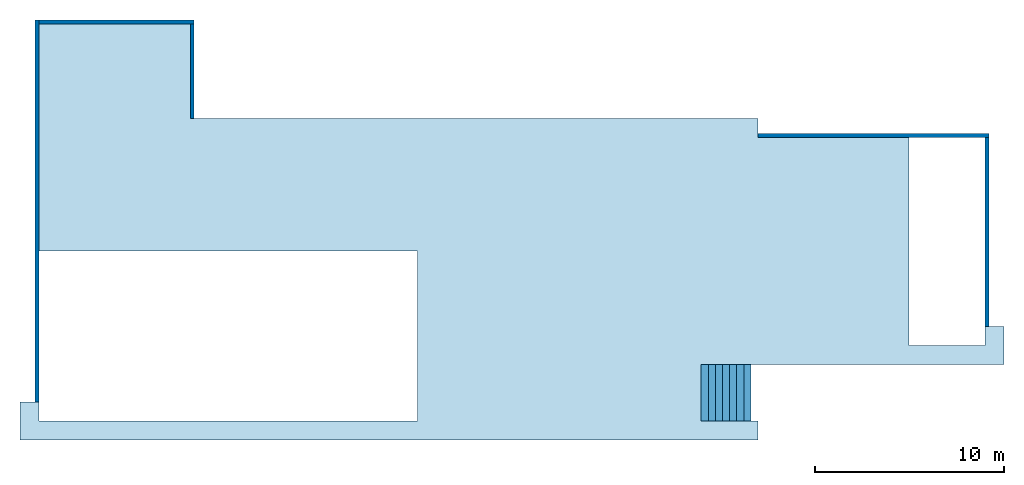
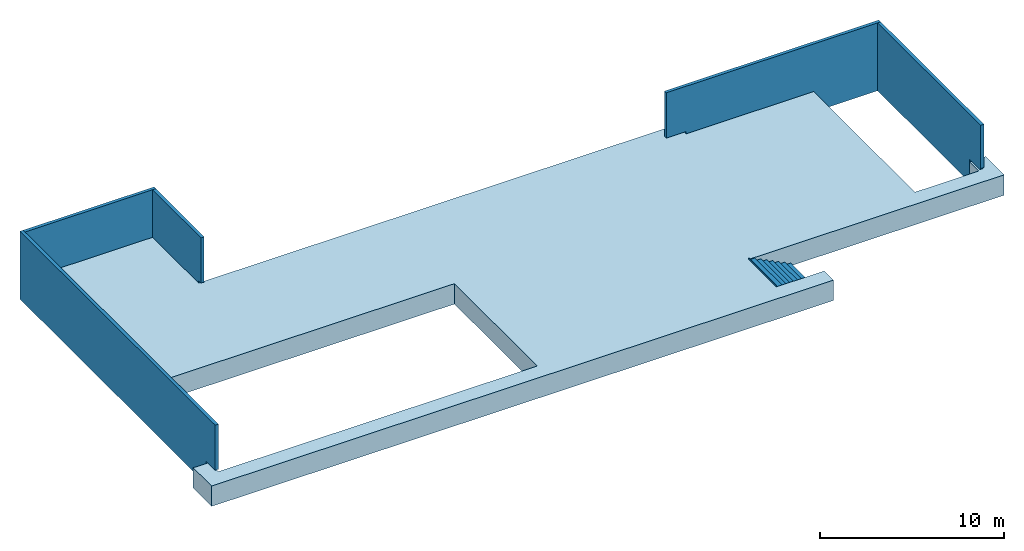
# One storey: 5 walls, 1 slab, 1 stair, 4 openings, 1 element without a shape of its own.
"""IFC2X3 building model written with IfcOpenShell, lengths in millimetres."""

from ifc_helpers import new_model, entity, si_unit, converted_unit, direction, frame, frame_2d, origin, place, context, subcontext, project, spatial, polyline, rectangle, outline, extrude, clip, halfspace, material, layer, layer_set, layer_usage, element, aggregate, save


model = new_model("IFC2X3")

# Units and contexts
model_context = context("Model", 3, precision=1e-06, world=origin(), true_north=direction((2.0, 6.12303176911189e-17, 1.0)))
context_of_model = context(None, 3, precision=1e-06, world=origin(), true_north=direction((2.0, 6.12303176911189e-17, 1.0)))
body_context = subcontext(model_context, "Body", "Model", "MODEL_VIEW")
ifc_project = project(units=[si_unit("LENGTHUNIT", "METRE", prefix="MILLI"), si_unit("AREAUNIT", "SQUARE_METRE", prefix="MILLI"), si_unit("VOLUMEUNIT", "CUBIC_METRE", prefix="MILLI"), converted_unit("PLANEANGLEUNIT", "DEGREE", entity("IfcRatioMeasure", 0.0174532925199433), si_unit("PLANEANGLEUNIT", "RADIAN"), dimensions=[0, 0, 0, 0, 0, 0, 0]), si_unit("TIMEUNIT", "SECOND")], contexts=[model_context, context_of_model])

# Site, building, storey
site_placement = place(None, origin())
site = spatial("IfcSite", under=ifc_project, at=site_placement, CompositionType="ELEMENT")
building_placement = place(site_placement, origin())
building = spatial("IfcBuilding", under=site, at=building_placement, CompositionType="ELEMENT")
storey_placement = place(building_placement, origin())
storey = spatial("IfcBuildingStorey", under=building, at=storey_placement, Name="Level 0", CompositionType="ELEMENT", Elevation=0.0)

# Slab
ifc_material_1 = material(Name="Default Floor")
ifc_layer_1 = layer(ifc_material_1, 1350.0)
ifc_layer_set_1 = layer_set([ifc_layer_1], Name="Floor:Generic 1350mm")
ifc_layer_usage_1 = layer_usage(ifc_layer_set_1, "AXIS3", "POSITIVE", 0.0)
slab_placement = place(storey_placement, origin())
element("IfcSlab", 1, at=slab_placement, inside=storey, material=ifc_layer_usage_1, Name="Floor:Generic 1350mm", ObjectType="Floor:Generic 1350mm", PredefinedType="FLOOR", context=body_context, shape_type="SweptSolid", body=[
    extrude(outline(polyline([(26000.0, -9000.0), (25000.0, -9000.0), (25000.0, -10000.0), (5000.0, -10000.0), (5000.0, -1000.0), (25000.0, -1000.0), (25000.0, 11000.0), (17000.0, 11000.0), (17000.0, 6000.0), (-13000.0, 6000.0), (-13000.0, 5000.0), (-20990.0, 5000.0), (-20990.0, -6000.0), (-25000.0, -6000.0), (-25000.0, -5000.0), (-26000.0, -5000.0), (-26000.0, -7000.0), (-10000.0, -7000.0), (-10000.0, -10000.0), (-13000.0, -10000.0), (-13000.0, -11000.0), (26000.0, -11000.0), (26000.0, -9000.0)])), frame((0.0, -100.0, 1350.0), z_axis=(0.0, 0.0, -1.0), x_axis=(-1.0, 0.0, 0.0)), (0.0, 0.0, 1.0), 1350.0),
])

# Wall, opening
ifc_material_2 = material(Name="Default Wall")
ifc_layer_2 = layer(ifc_material_2, 200.0)
ifc_layer_set_2 = layer_set([ifc_layer_2], Name="Basic Wall:Generic - 200mm")
ifc_layer_usage_2 = layer_usage(ifc_layer_set_2, "AXIS2", "NEGATIVE", 100.0)
wall_1_placement = place(storey_placement, frame((11750.0, 5000.0, 0.0)))
wall_1 = element("IfcWallStandardCase", 2, at=wall_1_placement, inside=storey, material=ifc_layer_usage_2, Name="Basic Wall:Generic - 200mm", ObjectType="Basic Wall:Generic - 200mm:398", context=body_context, shape_type="Clipping", body=[
    clip(extrude(rectangle(XDim=13450.0, YDim=200.0, at=frame_2d((6725.0, 1.63424829224823e-13), x_axis=(-1.0, 0.0))), origin(), (0.0, 0.0, 1.0), 4500.0), halfspace(frame((1250.0, 0.0, 0.0), z_axis=(-0.768221279597375, 0.0, -0.640184399664481), x_axis=(0.0, -1.0, 0.0)), False)),
])
opening_1_placement = place(wall_1_placement, frame((833.333333333333, 100.0, 1000.0)))
element("IfcOpeningElement", 3, at=opening_1_placement, cuts=wall_1, Name="Basic Wall:Generic - 200mm:2", ObjectType="Opening", context=body_context, shape_type="SweptSolid", body=[
    extrude(outline(polyline([(-1000.0, -416.666666666668), (500.0, -416.666666666668), (500.0, 833.333333333334), (-1000.0, -416.666666666668)])), frame((0.0, 0.0, 0.0), z_axis=(0.0, -1.0, 0.0), x_axis=(0.0, 0.0, 1.0)), (0.0, 0.0, 1.0), 200.0),
])

ifc_layer_usage_3 = layer_usage(ifc_layer_set_2, "AXIS2", "NEGATIVE", 100.0)
wall_2_placement = place(storey_placement, frame((25100.0, 4900.0, 0.0), z_axis=(0.0, 0.0, 1.0), x_axis=(0.0, -1.0, 0.0)))
wall_2 = element("IfcWallStandardCase", 4, at=wall_2_placement, inside=storey, material=ifc_layer_usage_3, Name="Basic Wall:Generic - 200mm", ObjectType="Basic Wall:Generic - 200mm:398", context=body_context, shape_type="Clipping", body=[
    clip(extrude(rectangle(XDim=11200.0, YDim=199.999999999998, at=frame_2d((5599.99999999998, 0.0), x_axis=(-1.0, 0.0))), origin(), (0.0, 0.0, 1.0), 4500.0), halfspace(frame((10000.0, 0.0, 0.0), z_axis=(0.806404995855705, 0.0, -0.591363663627518), x_axis=(0.0, 1.0, 0.0)), False)),
])
opening_2_placement = place(wall_2_placement, frame((10366.6666666666, 100.0, 1000.0)))
element("IfcOpeningElement", 5, at=opening_2_placement, cuts=wall_2, Name="Basic Wall:Generic - 200mm:2", ObjectType="Opening", context=body_context, shape_type="SweptSolid", body=[
    extrude(outline(polyline([(-1023.23833918579, -295.681831813759), (836.869184588035, -295.681831813759), (186.36915459776, 591.363663627517), (-1023.23833918579, -295.681831813759)])), frame((0.0, 0.0, 0.0), z_axis=(0.0, -1.0, 0.0), x_axis=(0.591363663627518, 0.0, 0.806404995855705)), (0.0, 0.0, 1.0), 200.0),
])

ifc_layer_usage_4 = layer_usage(ifc_layer_set_2, "AXIS2", "NEGATIVE", 100.0)
wall_3_placement = place(storey_placement, frame((-25100.0, -10100.0, 0.0), z_axis=(0.0, 0.0, 1.0), x_axis=(0.0, 1.0, 0.0)))
wall_3 = element("IfcWallStandardCase", 6, at=wall_3_placement, inside=storey, material=ifc_layer_usage_4, Name="Basic Wall:Generic - 200mm", ObjectType="Basic Wall:Generic - 200mm:398", context=body_context, shape_type="Clipping", body=[
    clip(extrude(rectangle(XDim=21200.0, YDim=199.999999999998, at=frame_2d((10600.0, -1.56319401867222e-13), x_axis=(-1.0, 0.0))), origin(), (0.0, 0.0, 1.0), 4500.0), halfspace(frame((1000.0, 0.0, 0.0), z_axis=(-0.806404995855712, 0.0, -0.591363663627508), x_axis=(0.0, -1.0, 0.0)), False)),
])
opening_3_placement = place(wall_3_placement, frame((633.333333333316, 100.0, 1000.0)))
element("IfcOpeningElement", 7, at=opening_3_placement, cuts=wall_3, Name="Basic Wall:Generic - 200mm:2", ObjectType="Opening", context=body_context, shape_type="SweptSolid", body=[
    extrude(outline(polyline([(-1000.0, -366.666666666657), (500.0, -366.666666666657), (500.0, 733.333333333314), (-1000.0, -366.666666666657)])), frame((0.0, 0.0, 0.0), z_axis=(0.0, -1.0, 0.0), x_axis=(0.0, 0.0, 1.0)), (0.0, 0.0, 1.0), 200.0),
])

# Wall
ifc_layer_usage_5 = layer_usage(ifc_layer_set_2, "AXIS2", "NEGATIVE", 100.0)
wall_4_placement = place(storey_placement, frame((-25000.0, 11000.0, 0.0)))
element("IfcWallStandardCase", 8, at=wall_4_placement, inside=storey, material=ifc_layer_usage_5, Name="Basic Wall:Generic - 200mm", ObjectType="Basic Wall:Generic - 200mm:398", context=body_context, shape_type="SweptSolid", body=[
    extrude(rectangle(XDim=8199.99999999997, YDim=199.999999999998, at=frame_2d((4099.99999999998, -3.33955085807247e-13), x_axis=(-1.0, 0.0))), origin(), (0.0, 0.0, 1.0), 4500.0),
])

# Wall, opening
ifc_layer_usage_6 = layer_usage(ifc_layer_set_2, "AXIS2", "NEGATIVE", 100.0)
wall_5_placement = place(storey_placement, frame((-16900.0, 10900.0, 0.0), z_axis=(0.0, 0.0, 1.0), x_axis=(0.0, -1.0, 0.0)))
wall_5 = element("IfcWallStandardCase", 9, at=wall_5_placement, inside=storey, material=ifc_layer_usage_6, Name="Basic Wall:Generic - 200mm", ObjectType="Basic Wall:Generic - 200mm:398", context=body_context, shape_type="Clipping", body=[
    clip(extrude(rectangle(XDim=5259.99999999997, YDim=199.999999999998, at=frame_2d((2629.99999999998, -1.56319401867222e-13), x_axis=(-1.0, 0.0))), origin(), (0.0, 0.0, 1.0), 4500.0), halfspace(frame((5000.0, 0.0, 0.0), z_axis=(0.98530802039963, 0.0, -0.170786723535999), x_axis=(0.0, 1.0, 0.0)), False)),
])
opening_4_placement = place(wall_5_placement, frame((5086.66666666657, 100.0, 1000.0)))
element("IfcOpeningElement", 10, at=opening_4_placement, cuts=wall_5, Name="Basic Wall:Generic - 200mm:2", ObjectType="Opening", context=body_context, shape_type="SweptSolid", body=[
    extrude(outline(polyline([(-1000.10953643942, -85.393361767999), (522.2570422794, -85.393361767999), (477.852494160022, 170.786723536001), (-1000.10953643942, -85.393361767999)])), frame((0.0, 0.0, 0.0), z_axis=(0.0, -1.0, 0.0), x_axis=(0.170786723535999, 0.0, 0.98530802039963)), (0.0, 0.0, 1.0), 200.0),
])

# Stairs
placement = place(storey_placement, origin())
stair_1 = element("IfcStair", 11, at=placement, inside=storey, Name="Stair:190mm max riser 250mm going", ObjectType="Stair:190mm max riser 250mm going", ShapeType="NOTDEFINED")
stair_2 = element("IfcStair", 12, at=placement, Name="Stair:190mm max riser 250mm going", ObjectType="Stair:190mm max riser 250mm going", ShapeType="NOTDEFINED", context=body_context, shape_type="SweptSolid", body=[
    extrude(rectangle(XDim=375.00000000001, YDim=3000.0, at=frame_2d((0.0, 1.02318153949454e-12), x_axis=(1.0, 0.0))), frame((12437.5, -8600.0, 137.5)), (0.0, 0.0, 1.0), 50.0),
    extrude(outline(polyline([(503.238754924118, -1261.1695489753), (640.738754924118, -1261.1695489753), (640.738754924118, -821.287216395334), (-451.820078785897, 1363.83045102469), (-621.761245075881, 1363.83045102469), (-621.761245075881, 988.830451024701), (-434.261245075881, 988.830451024708), (-434.261245075881, 613.830451024715), (-246.761245075881, 613.830451024709), (-246.761245075881, 238.830451024716), (-59.2612450758814, 238.830451024699), (-59.2612450758814, -136.169548975294), (128.238754924119, -136.169548975292), (128.238754924119, -511.169548975285), (315.738754924119, -511.169548975298), (315.738754924119, -886.16954897529), (503.238754924118, -886.16954897529), (503.238754924118, -1261.1695489753)])), frame((11351.3304510247, -10100.0, 640.738754924118), z_axis=(0.0, 1.0, 0.0), x_axis=(0.0, 0.0, -1.0)), (0.0, 0.0, 1.0), 3000.0),
    extrude(rectangle(XDim=374.999999999993, YDim=3000.0, at=frame_2d((0.0, 5.6843418860808e-13), x_axis=(1.0, 0.0))), frame((12062.5, -8600.0, 325.0)), (0.0, 0.0, 1.0), 50.0),
    extrude(rectangle(XDim=374.999999999993, YDim=3000.0, at=frame_2d((0.0, 5.6843418860808e-13), x_axis=(1.0, 0.0))), frame((11687.5, -8600.0, 512.5)), (0.0, 0.0, 1.0), 50.0),
    extrude(rectangle(XDim=374.999999999993, YDim=3000.0, at=frame_2d((0.0, 5.6843418860808e-13), x_axis=(1.0, 0.0))), frame((11312.5, -8600.0, 700.0)), (0.0, 0.0, 1.0), 50.0),
    extrude(rectangle(XDim=374.999999999993, YDim=3000.0, at=frame_2d((0.0, 5.6843418860808e-13), x_axis=(1.0, 0.0))), frame((10937.5, -8600.0, 887.5)), (0.0, 0.0, 1.0), 50.0),
    extrude(rectangle(XDim=374.999999999993, YDim=3000.0, at=frame_2d((0.0, 5.6843418860808e-13), x_axis=(1.0, 0.0))), frame((10562.5, -8600.0, 1075.0)), (0.0, 0.0, 1.0), 50.0),
    extrude(rectangle(XDim=374.999999999993, YDim=3000.0, at=frame_2d((0.0, 5.6843418860808e-13), x_axis=(1.0, 0.0))), frame((10187.5, -8600.0, 1262.5)), (0.0, 0.0, 1.0), 50.0),
    extrude(rectangle(XDim=3000.0, YDim=12.4999999999993, at=frame_2d((0.0, 1.0831335828243e-12), x_axis=(1.0, 0.0))), frame((12618.75, -8600.0, 0.0), z_axis=(0.0, 0.0, 1.0), x_axis=(0.0, -1.0, 0.0)), (0.0, 0.0, 1.0), 137.5),
    extrude(rectangle(XDim=3000.0, YDim=12.4999999999993, at=frame_2d((5.6843418860808e-13, 1.0831335828243e-12), x_axis=(1.0, 0.0))), frame((12243.75, -8600.0, 137.5), z_axis=(0.0, 0.0, 1.0), x_axis=(0.0, -1.0, 0.0)), (0.0, 0.0, 1.0), 187.5),
    extrude(rectangle(XDim=3000.0, YDim=12.4999999999993, at=frame_2d((5.6843418860808e-13, 1.0831335828243e-12), x_axis=(1.0, 0.0))), frame((11868.75, -8600.0, 325.0), z_axis=(0.0, 0.0, 1.0), x_axis=(0.0, -1.0, 0.0)), (0.0, 0.0, 1.0), 187.5),
    extrude(rectangle(XDim=3000.0, YDim=12.4999999999993, at=frame_2d((5.6843418860808e-13, 1.0831335828243e-12), x_axis=(1.0, 0.0))), frame((11493.75, -8600.0, 512.5), z_axis=(0.0, 0.0, 1.0), x_axis=(0.0, -1.0, 0.0)), (0.0, 0.0, 1.0), 187.5),
    extrude(rectangle(XDim=3000.0, YDim=12.4999999999993, at=frame_2d((5.6843418860808e-13, 1.0831335828243e-12), x_axis=(1.0, 0.0))), frame((11118.75, -8600.0, 700.0), z_axis=(0.0, 0.0, 1.0), x_axis=(0.0, -1.0, 0.0)), (0.0, 0.0, 1.0), 187.5),
    extrude(rectangle(XDim=3000.0, YDim=12.4999999999993, at=frame_2d((-5.6843418860808e-13, 1.0831335828243e-12), x_axis=(1.0, 0.0))), frame((10743.75, -8600.0, 887.5), z_axis=(0.0, 0.0, 1.0), x_axis=(0.0, -1.0, 0.0)), (0.0, 0.0, 1.0), 187.5),
    extrude(rectangle(XDim=3000.0, YDim=12.4999999999993, at=frame_2d((-4.54747350886464e-13, 1.0831335828243e-12), x_axis=(1.0, 0.0))), frame((9993.75000000001, -8600.0, 1262.5), z_axis=(0.0, 0.0, 1.0), x_axis=(0.0, -1.0, 0.0)), (0.0, 0.0, 1.0), 187.5),
    extrude(rectangle(XDim=3000.0, YDim=12.4999999999993, at=frame_2d((-5.6843418860808e-13, 1.0831335828243e-12), x_axis=(1.0, 0.0))), frame((10368.75, -8600.0, 1075.0), z_axis=(0.0, 0.0, 1.0), x_axis=(0.0, -1.0, 0.0)), (0.0, 0.0, 1.0), 187.5),
])
aggregate(stair_1, [stair_2])

save(model, "model.ifc")
